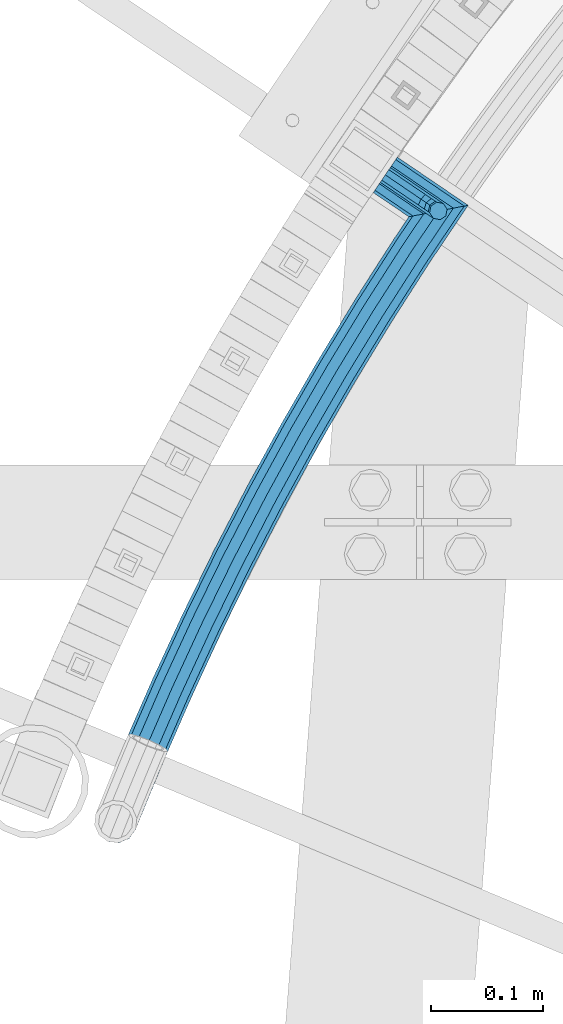
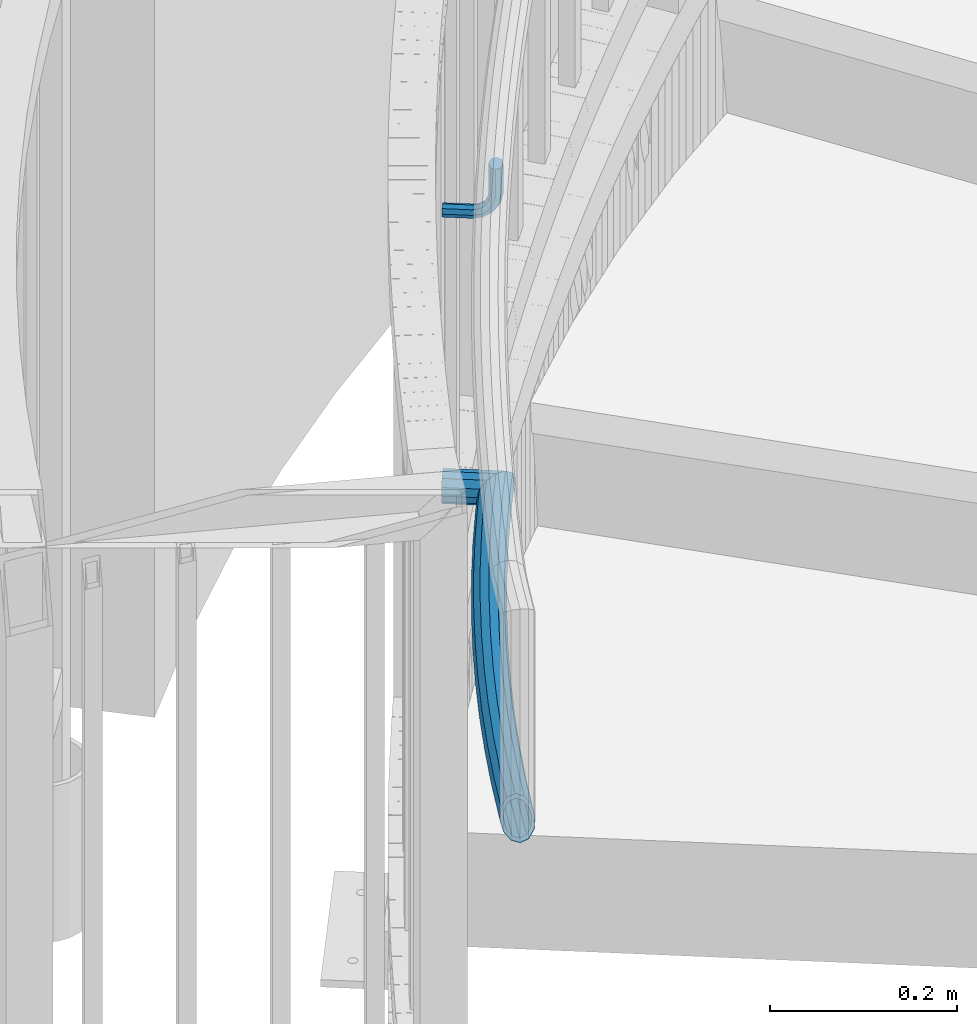
# One storey, part 479 of 975: 3 beams.
"""IFC2X3 building model written with IfcOpenShell, lengths in millimetres."""

from ifc_helpers import new_model, si_unit, frame, origin_with_axes, place, context, subcontext, project, spatial, faceted_brep, material, type_object, element, save


model = new_model("IFC2X3")

# Units and contexts
model_context = context("Model", 3, precision=1e-05, world=origin_with_axes())
body_context = subcontext(model_context, "Body", "Model", "MODEL_VIEW")
ifc_project = project(units=[si_unit("LENGTHUNIT", "METRE", prefix="MILLI"), si_unit("AREAUNIT", "SQUARE_METRE"), si_unit("VOLUMEUNIT", "CUBIC_METRE"), si_unit("MASSUNIT", "GRAM", prefix="KILO"), si_unit("TIMEUNIT", "SECOND"), si_unit("PLANEANGLEUNIT", "RADIAN"), si_unit("SOLIDANGLEUNIT", "STERADIAN"), si_unit("THERMODYNAMICTEMPERATUREUNIT", "DEGREE_CELSIUS"), si_unit("LUMINOUSINTENSITYUNIT", "LUMEN")], contexts=[model_context])

# Site, building, storey
site_placement = place(None, origin_with_axes())
site = spatial("IfcSite", under=ifc_project, at=site_placement, CompositionType="ELEMENT")
building_placement = place(site_placement, origin_with_axes())
building = spatial("IfcBuilding", under=site, at=building_placement, Name="Undefined", CompositionType="ELEMENT")
storey_placement = place(building_placement, origin_with_axes())
storey = spatial("IfcBuildingStorey", under=building, at=storey_placement, Name="Undefined", CompositionType="ELEMENT", Elevation=0.0)

# Beams
ifc_material_1 = material(Name="STEEL/A36")
beam_type_1 = type_object("IfcBeamType", PredefinedType="NOTDEFINED")
beam_1_placement = place(storey_placement, frame((32381.0561530064, 5001.78306185601, 988.576582992914), z_axis=(0.0, 0.0, 1.0), x_axis=(0.826997290974106, -0.562205905982399, 0.0)))
element("IfcBeam", 1, at=beam_1_placement, inside=storey, type_object=beam_type_1, material=ifc_material_1, Name="BRACKET", context=body_context, shape_type="Brep", body=[
    faceted_brep([(-4.22995071858168e-07, -7.93750000000728, 0.0), (-2.99107341561466e-07, -5.61266007567065, -5.61266007566792), (31.7499842270954, -5.6126618385606, -5.6126600757234), (31.7499840980236, -7.93750176289177, -5.54791768081486e-11), (-1.09139364212751e-11, 1.81898940354586e-12, -7.9375), (31.7499845387247, -1.7628881323617e-06, -7.93750000005548), (2.99089151667431e-07, 5.61266007567428, -5.61266007566792), (31.7499848503612, 5.61265831278433, -5.6126600757234), (4.22980519942939e-07, 7.93750000001091, 0.0), (31.7499849794513, 7.93749823711914, -5.54791768081486e-11), (2.99089151667431e-07, 5.61266007567428, 5.61266007566792), (31.7499848503794, 5.61265831278433, 5.61266007561244), (-1.09139364212751e-11, 1.81898940354586e-12, 7.9375), (31.7499845387538, -1.7628881323617e-06, 7.93749999994452), (-2.99107341561466e-07, -5.61266007567065, 5.61266007566792), (31.7499842271172, -5.6126618385606, 5.61266007561244), (44.5076933192395, -2.47124626184814e-06, -5.39983394420233), (43.618015285665, -5.61266249752225, -3.25196192174644), (41.4701431341346, -7.93750230259684, 1.9334598451087), (39.322271240766, -5.61266225900181, 7.11888161196475), (38.432593830461, -2.1339365048334e-06, 9.26675363442064), (39.3222718640282, 5.61265789233948, 7.11888161196475), (41.4701440155623, 7.93749769741771, 1.9334598451087), (43.6180159089272, 5.61265765382268, -3.25196192174644), (53.6792468227941, 5.61265709518557, 3.47073764605557), (55.32315658683, -3.07176742353477e-06, 1.82682757038583), (49.7104969518768, 7.93749723988003, 7.43948764606012), (45.7417468228014, 5.61265753590487, 11.4082376460638), (44.0978364355033, -2.44848706643097e-06, 13.0521477217335), (45.7417461995356, -5.61266261544006, 11.4082376460638), (49.7104960704528, -7.93750276013816, 7.43948764606012), (53.6792461995283, -5.612663056163, 3.47073764605648), (60.4019463906188, 5.61265672191075, 13.5319685599115), (62.5498181014409, -3.47302193404175e-06, 12.6422908379673), (55.2165247528465, 7.93749693416248, 15.6798405823693), (50.0311028569122, 5.61265729774459, 17.8277126048279), (47.8832305228243, -2.65866765403189e-06, 18.7173903267721), (50.03110223365, -5.61266285360034, 17.8277126048279), (55.2165238714188, -7.93750306585207, 15.6798405823693), (60.4019457673567, -5.61266342943782, 13.5319685599115), (62.7626445446149, 5.61265659083438, 25.3999996184748), (65.0874841573168, -3.61392449121922e-06, 25.3999996184748), (57.1499845980288, 7.93749682680573, 25.3999996184748), (51.5373243932772, 5.61265721410746, 25.3999996184748), (49.2124841573132, -2.73247496807016e-06, 25.3999996184748), (51.5373237700151, -5.61266293723384, 25.3999996184748), (57.1499837166011, -7.93750317320519, 25.3999996184748), (62.7626439213527, -5.61266356051055, 25.3999996184748), (65.0874827799671, -8.13710357761011e-07, 63.5532656203741), (62.7626427854739, -5.61266086031537, 61.7133802904182), (57.1499826807376, -7.93750071448449, 60.9512776088477), (51.5373226341253, -5.61266071998034, 61.7133869906074), (49.2124827799453, -6.15244061918929e-07, 63.5532750958728), (51.5373227744385, 5.61265943136095, 65.3931604258296), (57.1499828791711, 7.93749928552643, 66.1552631073992), (62.7626429257907, 5.61265929102228, 65.3931537256394)], [[[0, 1, 2, 3]], [[1, 4, 5, 2]], [[4, 6, 7, 5]], [[6, 8, 9, 7]], [[8, 10, 11, 9]], [[10, 12, 13, 11]], [[12, 14, 15, 13]], [[14, 0, 3, 15]], [[14, 12, 10, 8, 6, 4, 1, 0]], [[2, 5, 16, 17]], [[3, 2, 17, 18]], [[15, 3, 18, 19]], [[13, 15, 19, 20]], [[11, 13, 20, 21]], [[9, 11, 21, 22]], [[7, 9, 22, 23]], [[5, 7, 23, 16]], [[23, 24, 25, 16]], [[22, 26, 24, 23]], [[21, 27, 26, 22]], [[20, 28, 27, 21]], [[19, 29, 28, 20]], [[18, 30, 29, 19]], [[17, 31, 30, 18]], [[16, 25, 31, 17]], [[24, 32, 33, 25]], [[26, 34, 32, 24]], [[27, 35, 34, 26]], [[28, 36, 35, 27]], [[29, 37, 36, 28]], [[30, 38, 37, 29]], [[31, 39, 38, 30]], [[25, 33, 39, 31]], [[32, 40, 41, 33]], [[34, 42, 40, 32]], [[35, 43, 42, 34]], [[36, 44, 43, 35]], [[37, 45, 44, 36]], [[38, 46, 45, 37]], [[39, 47, 46, 38]], [[33, 41, 47, 39]], [[47, 41, 48, 49]], [[46, 47, 49, 50]], [[45, 46, 50, 51]], [[44, 45, 51, 52]], [[43, 44, 52, 53]], [[42, 43, 53, 54]], [[40, 42, 54, 55]], [[41, 40, 55, 48]], [[54, 53, 52, 51, 50, 49, 48, 55]]]),
])
ifc_material_2 = material()
beam_type_2 = type_object("IfcBeamType", PredefinedType="NOTDEFINED")
beam_2_placement = place(storey_placement, frame((32360.0533710274, 5016.06744034128, 628.65), z_axis=(0.56193729395384, 0.827179833932039, 0.0), x_axis=(0.82717983393204, -0.561937293953839, 0.0)))
element("IfcBeam", 2, at=beam_2_placement, inside=storey, type_object=beam_type_2, material=ifc_material_2, Name="HANDRAIL", context=body_context, shape_type="Brep", body=[
    faceted_brep([(25.4000003714245, -15.367, 2.91038304567337e-11), (25.3986753478639, -13.3082123799554, 7.68350000003556), (90.363403363066, -13.3082123799554, 7.68350000010469), (82.7115367184924, -15.367, 9.82254277914762e-11), (25.397705363288, -7.68349999999998, 13.3082123799904), (95.9649585196348, -7.68349999999998, 13.3082123800705), (25.397350324296, 0.0, 15.3670000000347), (98.015270007636, 0.0, 15.3670000001184), (25.397705363288, 7.68349999999998, 13.3082123799904), (95.9649585196348, 7.68349999999998, 13.3082123800705), (25.3986753478639, 13.3082123799554, 7.68350000003556), (90.363403363066, 13.3082123799554, 7.68350000010469), (25.4000003714245, 15.367, 2.91038304567337e-11), (82.7115367184924, 15.367, 9.82254277914762e-11), (25.4013253949925, 13.3082123799554, -7.68349999997008), (75.0596700739188, 13.3082123799554, -7.68349999991551), (25.4022953795647, 7.68349999999998, -13.3082123799286), (69.45811491735, 7.68349999999998, -13.3082123798777), (25.4026504185567, 0.0, -15.3669999999765), (67.4078034293489, 0.0, -15.366999999922), (25.4022953795647, -7.68349999999998, -13.3082123799286), (69.45811491735, -7.68349999999998, -13.3082123798777), (25.4013253949925, -13.3082123799554, -7.68349999997008), (75.0596700739188, -13.3082123799554, -7.68349999991551), (25.4000003714245, -19.05, 2.91038304567337e-11), (25.4016429626281, -16.4977839420935, -9.52499999996871), (73.2257516219179, -16.4977839420935, -9.52499999991414), (82.7115367184924, -19.05, 9.82254277914762e-11), (25.4028454228355, -9.52499999999998, -16.4977839420681), (66.2816749815429, -9.52499999999998, -16.4977839420208), (25.4032855538171, 0.0, -19.0499999999774), (63.7399665253361, 0.0, -19.0499999999338), (25.4028454228355, 9.52499999999998, -16.4977839420681), (66.2816749815429, 9.52499999999998, -16.4977839420208), (25.4016429626281, 16.4977839420935, -9.52499999996871), (73.2257516219179, 16.4977839420935, -9.52499999991414), (25.4000003714245, 19.05, 2.91038304567337e-11), (82.7115367184924, 19.05, 9.82254277914762e-11), (25.3983577802283, 16.4977839420935, 9.5250000000342), (92.1973218150706, 16.4977839420935, 9.52500000011059), (25.3971553200172, 9.52499999999998, 16.4977839421263), (99.1413984554456, 9.52499999999998, 16.4977839422136), (25.396715189032, 0.0, 19.0500000000357), (101.683106911645, 0.0, 19.050000000123), (25.3971553200172, -9.52499999999998, 16.4977839421263), (99.1413984554456, -9.52499999999998, 16.4977839422136), (25.3983577802283, -16.4977839420935, 9.5250000000342), (92.1973218150706, -16.4977839420935, 9.52500000011059)], [[[0, 1, 2, 3]], [[1, 4, 5, 2]], [[4, 6, 7, 5]], [[6, 8, 9, 7]], [[8, 10, 11, 9]], [[10, 12, 13, 11]], [[12, 14, 15, 13]], [[14, 16, 17, 15]], [[16, 18, 19, 17]], [[18, 20, 21, 19]], [[20, 22, 23, 21]], [[22, 0, 3, 23]], [[24, 25, 26, 27]], [[25, 28, 29, 26]], [[28, 30, 31, 29]], [[30, 32, 33, 31]], [[32, 34, 35, 33]], [[34, 36, 37, 35]], [[36, 38, 39, 37]], [[38, 40, 41, 39]], [[40, 42, 43, 41]], [[42, 44, 45, 43]], [[44, 46, 47, 45]], [[46, 24, 27, 47]], [[29, 31, 33, 35, 37, 39, 41, 43, 45, 47, 27, 26], [5, 7, 9, 11, 13, 15, 17, 19, 21, 23, 3, 2]], [[46, 44, 42, 40, 38, 36, 34, 32, 30, 28, 25, 24], [22, 20, 18, 16, 14, 12, 10, 8, 6, 4, 1, 0]]]),
])
beam_3_placement = place(storey_placement, frame((32141.6837100169, 4427.4633907106, 628.65), z_axis=(-0.882285894078021, 0.470713927041624, 0.0), x_axis=(0.470713927041624, 0.882285894078021, 0.0)))
element("IfcBeam", 3, at=beam_3_placement, inside=storey, type_object=beam_type_2, material=ifc_material_2, Name="HANDRAIL", context=body_context, shape_type="Brep", body=[
    faceted_brep([(64.0961737371654, -16.4977839420935, -2.97746911529975), (64.7309998214369, -9.52499999999998, -9.92129455562463), (127.717061341729, -9.52499999999998, -4.88599295249514), (127.240653001059, -16.4977839420935, 2.07049689482301), (190.801519875513, -9.52499999999998, -1.28747942989503), (190.483776759109, -16.4977839420935, 5.67806112450126), (253.951604828992, -9.52499999999998, 0.872376686067582), (253.79269199543, -16.4977839420935, 7.84334954603037), (317.134511517299, -9.52499999999998, 1.59245341118367), (317.134511517303, -16.4977839420935, 8.56523735326846), (380.317418205606, -9.52499999999998, 0.872376685929339), (380.476331039175, -16.4977839420935, 7.84334954589212), (443.467503159085, -9.52499999999998, -1.28747943018243), (443.785246275493, -16.4977839420935, 5.67806112422113), (506.551961692865, -9.52499999999998, -4.88599295291715), (507.028370033542, -16.4977839420935, 2.07049689440464), (569.538023213157, -9.52499999999998, -9.92129455618488), (570.172849297429, -16.4977839420935, -2.97746911586), (506.377584137601, 0.0, -7.43224495820323), (569.305660739326, 0.0, -12.4629110667884), (443.351201106601, 0.0, -3.83704422417941), (380.25925207153, 0.0, -1.67917646990827), (317.134511517299, 0.0, -0.959762646718445), (254.009770963065, 0.0, -1.67917646977003), (190.917821927997, 0.0, -3.83704422389928), (127.89143889699, 0.0, -7.4322449577885), (64.9633622952642, 0.0, -12.4629110662318), (2.16628148061136, 0.0, -18.926429260322), (1.87605479395643, 9.52499999999998, -16.3907685423692), (64.7309998214369, 9.52499999999998, -9.92129455562463), (127.717061341729, 9.52499999999998, -4.88599295249514), (190.801519875513, 9.52499999999998, -1.28747942989503), (253.951604828992, 9.52499999999998, 0.872376686067582), (317.134511517299, 9.52499999999998, 1.59245341118367), (380.317418205606, 9.52499999999998, 0.872376685929339), (443.467503159085, 9.52499999999998, -1.28747943018243), (506.551961692865, 9.52499999999998, -4.88599295291715), (569.538023213157, 9.52499999999998, -9.92129455618488), (507.028370033542, 16.4977839420935, 2.07049689440464), (570.172849297429, 16.4977839420935, -2.97746911586), (443.785246275493, 16.4977839420935, 5.67806112422113), (380.476331039175, 16.4977839420935, 7.84334954589212), (317.134511517303, 16.4977839420935, 8.56523735326846), (253.79269199543, 16.4977839420935, 7.84334954603037), (190.483776759109, 16.4977839420935, 5.67806112450126), (127.240653001059, 16.4977839420935, 2.07049689482301), (64.0961737371654, 16.4977839420935, -2.97746911529975), (1.08314074030568, 16.4977839420935, -9.4632146301592), (2.63382389675826e-07, 19.0500000000138, 0.0), (63.2289851790702, 19.05, 6.50797283563224), (126.589867105122, 19.05, 11.5732387474382), (190.049731590225, 19.05, 15.1931664728982), (253.575613027791, 19.05, 17.3658755618308), (317.134511517306, 19.05, 18.0902373532517), (380.693410006817, 19.05, 17.3658755616889), (444.219291444384, 19.05, 15.193166472618), (507.679155929483, 19.05, 11.5732387470161), (571.040037855535, 19.05, 6.50797283506836), (508.329941825425, 16.4977839420935, 21.0759805996277), (571.907226413638, 16.4977839420935, 15.9934147860004), (444.653336613275, 16.4977839420935, 24.7082718210149), (380.910488974463, 16.4977839420935, 26.8884015774893), (317.134511517306, 16.4977839420935, 27.6152373532423), (253.358534060153, 16.4977839420935, 26.8884015776275), (189.615686421337, 16.4977839420935, 24.7082718212951), (125.939081209188, 16.4977839420935, 21.0759806000533), (62.3617966209749, 16.4977839420935, 15.9934147865606), (-1.08314074030568, 16.4977839420935, 9.4632146301592), (-1.87605479395643, 9.52499999999998, 16.3907685423655), (-2.16628148061136, 0.0, 18.9264292603184), (61.4946080628761, 0.0, 25.4788567374926), (61.7269705367034, 9.52499999999998, 22.9372402268891), (125.462672868518, 9.52499999999998, 28.0324704473787), (189.297943304933, 9.52499999999998, 31.673812375695), (253.199621226591, 9.52499999999998, 33.8593744375867), (317.134511517314, 9.52499999999998, 34.5880212953271), (381.069401808028, 9.52499999999998, 33.8593744374484), (444.971079729687, 9.52499999999998, 31.6738123754112), (508.806350166102, 9.52499999999998, 28.0324704469531), (572.542052497909, 9.52499999999998, 22.9372402263216), (508.980727721366, 0.0, 30.5787224522392), (572.77441497174, 0.0, 25.4788567369287), (445.08738178217, 0.0, 34.2233771694155), (381.127567942105, 0.0, 36.410927593286), (317.134511517314, 0.0, 37.1402373532292), (253.141455092518, 0.0, 36.4109275934279), (189.181641252453, 0.0, 34.2233771696956), (125.288295313254, 0.0, 30.5787224526684), (61.7269705367034, -9.52499999999998, 22.9372402268891), (125.462672868518, -9.52499999999998, 28.0324704473787), (189.297943304933, -9.52499999999998, 31.673812375695), (253.199621226591, -9.52499999999998, 33.8593744375867), (317.134511517314, -9.52499999999998, 34.5880212953271), (381.069401808028, -9.52499999999998, 33.8593744374484), (444.971079729687, -9.52499999999998, 31.6738123754112), (508.806350166102, -9.52499999999998, 28.0324704469531), (572.542052497909, -9.52499999999998, 22.9372402263216), (508.329941825425, -16.4977839420935, 21.0759805996277), (571.907226413638, -16.4977839420935, 15.9934147860004), (444.653336613275, -16.4977839420935, 24.7082718210149), (380.910488974463, -16.4977839420935, 26.8884015774893), (317.134511517306, -16.4977839420935, 27.6152373532423), (253.358534060153, -16.4977839420935, 26.8884015776275), (189.615686421337, -16.4977839420935, 24.7082718212951), (125.939081209188, -16.4977839420935, 21.0759806000533), (62.3617966209749, -16.4977839420935, 15.9934147865606), (63.2289851790702, -19.05, 6.50797283563224), (126.589867105122, -19.05, 11.5732387474382), (190.049731590225, -19.05, 15.1931664728982), (253.575613027791, -19.05, 17.3658755618308), (317.134511517306, -19.05, 18.0902373532517), (380.693410006817, -19.05, 17.3658755616889), (444.219291444384, -19.05, 15.193166472618), (507.679155929483, -19.05, 11.5732387470161), (571.040037855535, -19.05, 6.50797283506836), (613.304175128596, -19.05, 2.15784992037152), (604.842787256781, -16.4977839420935, 12.6034547116578), (598.648621432061, -9.52499999999998, 20.2501681346657), (596.381399384962, 0.0, 23.0490595029441), (598.648621432061, 9.52499999999998, 20.2501681346657), (604.842787256781, 16.4977839420935, 12.6034547116578), (613.304175128596, 19.05, 2.15784992037152), (621.765563000412, 16.4977839420935, -8.28775487091116), (627.959728825128, 9.52499999999998, -15.9344682939191), (630.226950872227, 0.0, -18.7333596621938), (627.959728825128, -9.52499999999998, -15.9344682939191), (621.765563000412, -16.4977839420935, -8.28775487091116), (17.5583429933322, -19.05, 1.80722842404793), (16.1049577393569, -16.4977839420935, -7.91706334060655), (9.96318364445688, -9.52499999999998, -15.5583842374763), (2.12377757901049, -1.39494292340862, -18.5550799716366), (0.782327375163732, 0.0, -19.1008339097352), (-8.95913991405541, 9.52499999999998, -17.7562100168943), (-16.6721171323625, 16.4977839420935, -11.7007162296759), (-20.2899182628717, 19.05, -2.55691721814583), (-18.8431564142884, 16.4977839420935, 7.22511345680323), (-12.7194902555821, 9.52499999999998, 15.0242885754924), (-3.55975118869173, 0.0, 18.7508254632303), (-2.12349110913055, -1.40434462813937, 18.5525771334869), (6.20281172824252, -9.52499999999998, 17.2223024301893), (13.933906001279, -16.4977839420935, 11.0088749311908), (1.51335086712425, 7.68349999999998, -13.2218866241783), (1.74746706102451, 0.0, -15.2673196033247), (64.6280493861304, 0.0, -8.79520684520321), (64.4406103239126, 7.68349999999998, -6.7449695266514), (0.873733530512254, 13.3082123799554, -7.63365980166054), (63.9285172825985, 13.3082123799554, -1.14361700478548), (2.12461600312963e-07, 15.3670000000093, 0.0), (63.2289851790702, 15.367, 6.50797283563224), (-0.873733530512254, 13.3082123799554, 7.63365980166054), (62.5294530755382, 13.3082123799554, 14.15956267605), (-1.51335086712425, 7.68349999999998, 13.2218866241747), (62.0173600342277, 7.68349999999998, 19.7609151979123), (-1.74746706102815, 0.0, 15.2673196033211), (61.8299209720062, 0.0, 21.8111525164677), (62.0173600342277, -7.68349999999998, 19.7609151979123), (62.5294530755382, -13.3082123799554, 14.15956267605), (10.9708303010448, -13.3082123799554, 8.85278579976512), (4.73441425412966, -7.68349999999998, 13.8649506489601), (-1.70470493584799, -1.40341760792103, 14.8937142595641), (-3.14001692751845, 0.0, 15.0918317238429), (-10.5288731081419, 7.68349999999998, 12.0857586344027), (-15.4686304761672, 13.3082123799554, 5.79442403866415), (-16.6356850340235, 15.367, -2.09641403913702), (-13.7173254554145, 13.3082123799554, -9.47241190843488), (-7.49552383264381, 7.68349999999998, -14.3571768967886), (0.36259311399408, 0.0, -15.4418401703515), (1.70493490931403, -1.39587006868669, -14.8957234982809), (64.4406103239126, -7.68349999999998, -6.7449695266514), (7.76778093320536, -7.68349999999998, -12.5781365962903), (63.9285172825985, -13.3082123799554, -1.14361700478548), (12.7221453697603, -13.3082123799554, -6.41413773948079), (63.2289851790702, -15.367, 6.50797283563224), (13.8945428079642, -15.367, 1.43012428400834), (126.064899815738, -13.3082123799554, 19.2387838418799), (126.589867105122, -15.367, 11.5732387474382), (127.11483439451, -13.3082123799554, 3.90769365299639), (127.499137122653, -7.68349999999998, -1.70387482384467), (127.639801683898, 0.0, -3.75785144144174), (127.499137122653, 7.68349999999998, -1.70387482384467), (127.11483439451, 13.3082123799554, 3.90769365299639), (126.589867105122, 15.367, 11.5732387474382), (126.064899815738, 13.3082123799554, 19.2387838418799), (125.680597087594, 7.68349999999998, 24.8503523187246), (125.53993252635, 0.0, 26.9043289363217), (125.680597087594, -7.68349999999998, 24.8503523187246), (189.443289040089, -7.68349999999998, 28.487554167823), (189.699601820656, -13.3082123799554, 22.8686847872705), (190.049731590225, -15.367, 15.1931664728982), (190.399861359794, -13.3082123799554, 7.51764815852221), (190.656174140357, -7.68349999999998, 1.89877877797699), (190.74999112936, 0.0, -0.157870155853743), (190.656174140357, 7.68349999999998, 1.89877877797699), (190.399861359794, 13.3082123799554, 7.51764815852221), (190.049731590225, 15.367, 15.1931664728982), (189.699601820656, 13.3082123799554, 22.8686847872705), (189.443289040089, 7.68349999999998, 28.487554167823), (189.34947205109, 0.0, 30.5442031016464), (253.225392293338, 0.0, 32.7288842006492), (253.272312974823, -7.68349999999998, 30.6706313216127), (253.400502660563, -13.3082123799554, 25.0473798812418), (253.575613027791, -15.367, 17.3658755618308), (253.75072339502, -13.3082123799554, 9.68437124241609), (253.87891308076, -7.68349999999998, 4.06111980204878), (253.925833762249, 0.0, 2.0028669230087), (253.87891308076, 7.68349999999998, 4.06111980204878), (253.75072339502, 13.3082123799554, 9.68437124241609), (253.575613027791, 15.367, 17.3658755618308), (253.400502660563, 13.3082123799554, 25.0473798812418), (253.272312974823, 7.68349999999998, 30.6706313216127), (317.13451151731, 7.68349999999998, 31.3984497331912), (317.13451151731, 0.0, 33.4572373532355), (317.13451151731, -7.68349999999998, 31.3984497331912), (317.13451151731, -13.3082123799554, 25.7737373532436), (317.134511517306, -15.367, 18.0902373532517), (317.134511517303, -13.3082123799554, 10.4067373532707), (317.134511517303, -7.68349999999998, 4.78202497331586), (317.134511517299, 0.0, 2.72323735327882), (317.134511517303, 7.68349999999998, 4.78202497331586), (317.134511517303, 13.3082123799554, 10.4067373532707), (317.134511517306, 15.367, 18.0902373532517), (317.13451151731, 13.3082123799554, 25.7737373532436), (380.86852037405, 13.3082123799554, 25.0473798810999), (380.996710059797, 7.68349999999998, 30.6706313214672), (381.043630741282, 0.0, 32.7288842005109), (380.996710059797, -7.68349999999998, 30.6706313214672), (380.86852037405, -13.3082123799554, 25.0473798810999), (380.693410006817, -15.367, 17.3658755616889), (380.518299639585, -13.3082123799554, 9.68437124228149), (380.390109953842, -7.68349999999998, 4.06111980191054), (380.343189272353, 0.0, 2.00286692287045), (380.390109953842, 7.68349999999998, 4.06111980191054), (380.518299639585, 13.3082123799554, 9.68437124228149), (380.693410006817, 15.367, 17.3658755616889), (444.219291444384, 15.367, 15.193166472618), (444.569421213961, 13.3082123799554, 22.8686847869903), (444.825733994527, 7.68349999999998, 28.4875541675356), (444.919550983534, 0.0, 30.5442031013627), (444.825733994527, -7.68349999999998, 28.4875541675356), (444.569421213961, -13.3082123799554, 22.8686847869903), (444.219291444384, -15.367, 15.193166472618), (443.869161674811, -13.3082123799554, 7.51764815823844), (443.612848894241, -7.68349999999998, 1.89877877769322), (443.519031905238, 0.0, -0.157870156133868), (443.612848894241, 7.68349999999998, 1.89877877769322), (443.869161674811, 13.3082123799554, 7.51764815823844), (507.154188640092, 13.3082123799554, 3.90769365257802), (507.679155929483, 15.367, 11.5732387470161), (508.204123218875, 13.3082123799554, 19.2387838414543), (508.588425947022, 7.68349999999998, 24.850352318299), (508.729090508266, 0.0, 26.9043289358997), (508.588425947022, -7.68349999999998, 24.850352318299), (508.204123218875, -13.3082123799554, 19.2387838414543), (507.679155929483, -15.367, 11.5732387470161), (507.154188640092, -13.3082123799554, 3.90769365257802), (506.769885911945, -7.68349999999998, -1.70387482426304), (506.6292213507, 0.0, -3.75785144186375), (506.769885911945, 7.68349999999998, -1.70387482426304), (569.828412710682, 7.68349999999998, -6.74496952721165), (570.340505751996, 13.3082123799554, -1.14361700534573), (571.040037855535, 15.367, 6.50797283506836), (571.739569959067, 13.3082123799554, 14.1595626754861), (572.251663000385, 7.68349999999998, 19.7609151973484), (572.439102062606, 0.0, 21.8111525159002), (572.251663000385, -7.68349999999998, 19.7609151973484), (571.739569959067, -13.3082123799554, 14.1595626754861), (571.040037855535, -15.367, 6.50797283506836), (570.340505751996, -13.3082123799554, -1.14361700534573), (569.828412710682, -7.68349999999998, -6.74496952721165), (569.64097364846, 0.0, -8.79520684576346), (626.955214228459, 0.0, -14.6943924762345), (625.126321777134, 7.68349999999998, -12.4366201058183), (620.129694678526, 13.3082123799554, -6.26827127793149), (613.304175128596, 15.367, 2.15784992037152), (606.478655578663, 13.3082123799554, 10.5839711186745), (601.482028480059, 7.68349999999998, 16.7523199465686), (599.653136028734, 0.0, 19.0100923169775), (601.482028480059, -7.68349999999998, 16.7523199465686), (606.478655578663, -13.3082123799554, 10.5839711186745), (613.304175128596, -15.367, 2.15784992037152), (620.129694678526, -13.3082123799554, -6.26827127793149), (625.126321777134, -7.68349999999998, -12.4366201058183)], [[[0, 1, 2, 3]], [[3, 2, 4, 5]], [[5, 4, 6, 7]], [[7, 6, 8, 9]], [[9, 8, 10, 11]], [[11, 10, 12, 13]], [[13, 12, 14, 15]], [[15, 14, 16, 17]], [[14, 18, 19, 16]], [[12, 20, 18, 14]], [[10, 21, 20, 12]], [[8, 22, 21, 10]], [[6, 23, 22, 8]], [[4, 24, 23, 6]], [[2, 25, 24, 4]], [[1, 26, 25, 2]], [[27, 28, 29, 26]], [[26, 29, 30, 25]], [[25, 30, 31, 24]], [[24, 31, 32, 23]], [[23, 32, 33, 22]], [[22, 33, 34, 21]], [[21, 34, 35, 20]], [[20, 35, 36, 18]], [[18, 36, 37, 19]], [[36, 38, 39, 37]], [[35, 40, 38, 36]], [[34, 41, 40, 35]], [[33, 42, 41, 34]], [[32, 43, 42, 33]], [[31, 44, 43, 32]], [[30, 45, 44, 31]], [[29, 46, 45, 30]], [[28, 47, 46, 29]], [[47, 48, 49, 46]], [[46, 49, 50, 45]], [[45, 50, 51, 44]], [[44, 51, 52, 43]], [[43, 52, 53, 42]], [[42, 53, 54, 41]], [[41, 54, 55, 40]], [[40, 55, 56, 38]], [[38, 56, 57, 39]], [[56, 58, 59, 57]], [[55, 60, 58, 56]], [[54, 61, 60, 55]], [[53, 62, 61, 54]], [[52, 63, 62, 53]], [[51, 64, 63, 52]], [[50, 65, 64, 51]], [[49, 66, 65, 50]], [[48, 67, 66, 49]], [[68, 69, 70, 71]], [[67, 68, 71, 66]], [[66, 71, 72, 65]], [[65, 72, 73, 64]], [[64, 73, 74, 63]], [[63, 74, 75, 62]], [[62, 75, 76, 61]], [[61, 76, 77, 60]], [[60, 77, 78, 58]], [[58, 78, 79, 59]], [[78, 80, 81, 79]], [[77, 82, 80, 78]], [[76, 83, 82, 77]], [[75, 84, 83, 76]], [[74, 85, 84, 75]], [[73, 86, 85, 74]], [[72, 87, 86, 73]], [[71, 70, 87, 72]], [[70, 88, 89, 87]], [[87, 89, 90, 86]], [[86, 90, 91, 85]], [[85, 91, 92, 84]], [[84, 92, 93, 83]], [[83, 93, 94, 82]], [[82, 94, 95, 80]], [[80, 95, 96, 81]], [[95, 97, 98, 96]], [[94, 99, 97, 95]], [[93, 100, 99, 94]], [[92, 101, 100, 93]], [[91, 102, 101, 92]], [[90, 103, 102, 91]], [[89, 104, 103, 90]], [[88, 105, 104, 89]], [[105, 106, 107, 104]], [[104, 107, 108, 103]], [[103, 108, 109, 102]], [[102, 109, 110, 101]], [[101, 110, 111, 100]], [[100, 111, 112, 99]], [[99, 112, 113, 97]], [[97, 113, 114, 98]], [[98, 114, 115, 116]], [[96, 98, 116, 117]], [[81, 96, 117, 118]], [[79, 81, 118, 119]], [[59, 79, 119, 120]], [[57, 59, 120, 121]], [[39, 57, 121, 122]], [[37, 39, 122, 123]], [[19, 37, 123, 124]], [[16, 19, 124, 125]], [[17, 16, 125, 126]], [[114, 17, 126, 115]], [[113, 15, 17, 114]], [[112, 13, 15, 113]], [[111, 11, 13, 112]], [[110, 9, 11, 111]], [[109, 7, 9, 110]], [[108, 5, 7, 109]], [[107, 3, 5, 108]], [[106, 0, 3, 107]], [[0, 106, 127, 128]], [[1, 0, 128, 129]], [[27, 26, 1, 129, 130]], [[27, 130, 131]], [[28, 27, 131, 132]], [[47, 28, 132, 133]], [[48, 47, 133, 134]], [[67, 48, 134, 135]], [[68, 67, 135, 136]], [[69, 68, 136, 137]], [[69, 137, 138]], [[88, 70, 69, 138, 139]], [[105, 88, 139, 140]], [[106, 105, 140, 127]], [[141, 142, 143, 144]], [[145, 141, 144, 146]], [[147, 145, 146, 148]], [[149, 147, 148, 150]], [[151, 149, 150, 152]], [[153, 151, 152, 154]], [[155, 156, 157, 158]], [[153, 154, 155, 158, 159]], [[153, 159, 160]], [[151, 153, 160, 161]], [[149, 151, 161, 162]], [[147, 149, 162, 163]], [[145, 147, 163, 164]], [[141, 145, 164, 165]], [[142, 141, 165, 166]], [[142, 166, 167]], [[168, 143, 142, 167, 169]], [[170, 168, 169, 171]], [[172, 170, 171, 173]], [[139, 138, 137, 136, 135, 134, 133, 132, 131, 130, 129, 128, 127, 140], [169, 167, 166, 165, 164, 163, 162, 161, 160, 159, 158, 157, 173, 171]], [[156, 172, 173, 157]], [[172, 156, 174, 175]], [[170, 172, 175, 176]], [[168, 170, 176, 177]], [[143, 168, 177, 178]], [[144, 143, 178, 179]], [[146, 144, 179, 180]], [[148, 146, 180, 181]], [[150, 148, 181, 182]], [[152, 150, 182, 183]], [[154, 152, 183, 184]], [[155, 154, 184, 185]], [[156, 155, 185, 174]], [[174, 185, 186, 187]], [[175, 174, 187, 188]], [[176, 175, 188, 189]], [[177, 176, 189, 190]], [[178, 177, 190, 191]], [[179, 178, 191, 192]], [[180, 179, 192, 193]], [[181, 180, 193, 194]], [[182, 181, 194, 195]], [[183, 182, 195, 196]], [[184, 183, 196, 197]], [[185, 184, 197, 186]], [[186, 197, 198, 199]], [[187, 186, 199, 200]], [[188, 187, 200, 201]], [[189, 188, 201, 202]], [[190, 189, 202, 203]], [[191, 190, 203, 204]], [[192, 191, 204, 205]], [[193, 192, 205, 206]], [[194, 193, 206, 207]], [[195, 194, 207, 208]], [[196, 195, 208, 209]], [[197, 196, 209, 198]], [[198, 209, 210, 211]], [[199, 198, 211, 212]], [[200, 199, 212, 213]], [[201, 200, 213, 214]], [[202, 201, 214, 215]], [[203, 202, 215, 216]], [[204, 203, 216, 217]], [[205, 204, 217, 218]], [[206, 205, 218, 219]], [[207, 206, 219, 220]], [[208, 207, 220, 221]], [[209, 208, 221, 210]], [[210, 221, 222, 223]], [[211, 210, 223, 224]], [[212, 211, 224, 225]], [[213, 212, 225, 226]], [[214, 213, 226, 227]], [[215, 214, 227, 228]], [[216, 215, 228, 229]], [[217, 216, 229, 230]], [[218, 217, 230, 231]], [[219, 218, 231, 232]], [[220, 219, 232, 233]], [[221, 220, 233, 222]], [[222, 233, 234, 235]], [[223, 222, 235, 236]], [[224, 223, 236, 237]], [[225, 224, 237, 238]], [[226, 225, 238, 239]], [[227, 226, 239, 240]], [[228, 227, 240, 241]], [[229, 228, 241, 242]], [[230, 229, 242, 243]], [[231, 230, 243, 244]], [[232, 231, 244, 245]], [[233, 232, 245, 234]], [[234, 245, 246, 247]], [[235, 234, 247, 248]], [[236, 235, 248, 249]], [[237, 236, 249, 250]], [[238, 237, 250, 251]], [[239, 238, 251, 252]], [[240, 239, 252, 253]], [[241, 240, 253, 254]], [[242, 241, 254, 255]], [[243, 242, 255, 256]], [[244, 243, 256, 257]], [[245, 244, 257, 246]], [[246, 257, 258, 259]], [[247, 246, 259, 260]], [[248, 247, 260, 261]], [[249, 248, 261, 262]], [[250, 249, 262, 263]], [[251, 250, 263, 264]], [[252, 251, 264, 265]], [[253, 252, 265, 266]], [[254, 253, 266, 267]], [[255, 254, 267, 268]], [[256, 255, 268, 269]], [[257, 256, 269, 258]], [[258, 269, 270, 271]], [[259, 258, 271, 272]], [[260, 259, 272, 273]], [[261, 260, 273, 274]], [[262, 261, 274, 275]], [[263, 262, 275, 276]], [[264, 263, 276, 277]], [[265, 264, 277, 278]], [[266, 265, 278, 279]], [[267, 266, 279, 280]], [[268, 267, 280, 281]], [[269, 268, 281, 270]], [[122, 121, 120, 119, 118, 117, 116, 115, 126, 125, 124, 123], [280, 279, 278, 277, 276, 275, 274, 273, 272, 271, 270, 281]]]),
])

save(model, "model.ifc")
